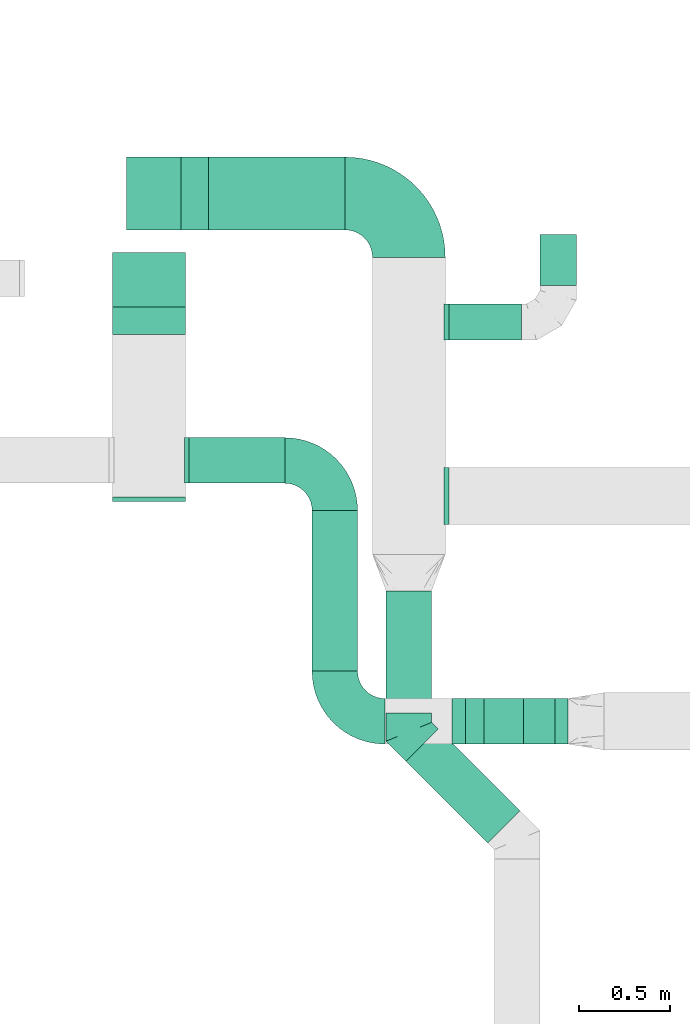
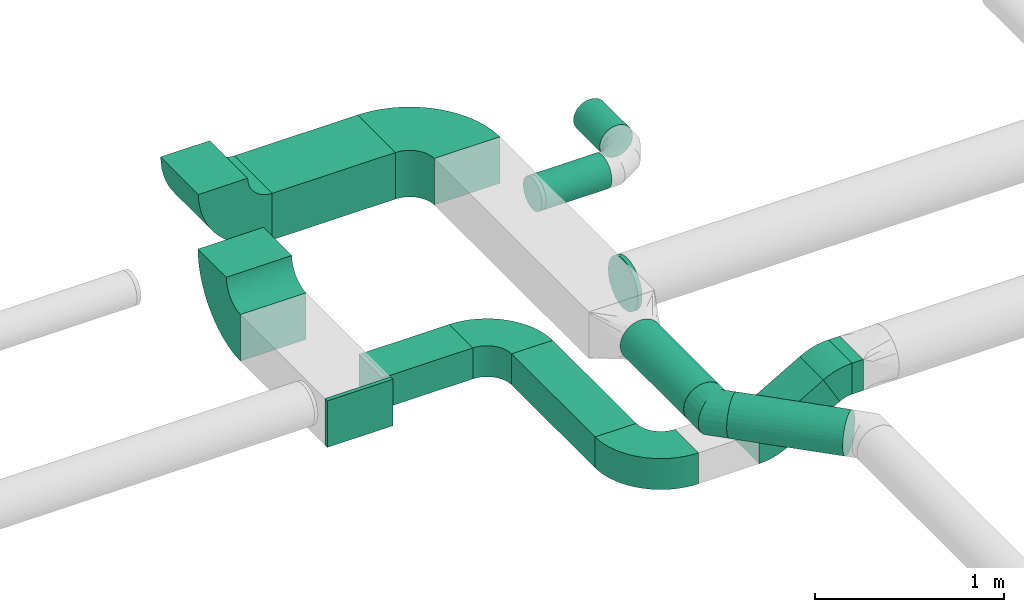
# One storey, part 45 of 92: 12 flow fittings, 9 flow segments.
"""IFC2X3 building model written with IfcOpenShell, lengths in millimetres."""

from ifc_helpers import new_model, entity, si_unit, converted_unit, derived_unit, direction, frame, frame_2d, origin, origin_2d_with_axis, place, context, subcontext, project, spatial, polyline, circle_curve, parameter, trimmed, segment, composite_curve, rectangle, circle, outline, extrude, faceted_brep, source, transform, mapped, material, type_object, type_shapes, element, save


model = new_model("IFC2X3")

# Units and contexts
model_context = context("Model", 3, precision=0.01, world=origin(), true_north=direction((6.12303176911189e-17, 1.0)))
body_context = subcontext(model_context, "Body", "Model", "MODEL_VIEW")
ifc_project = project(units=[si_unit("LENGTHUNIT", "METRE", prefix="MILLI"), si_unit("AREAUNIT", "SQUARE_METRE"), si_unit("VOLUMEUNIT", "CUBIC_METRE"), converted_unit("PLANEANGLEUNIT", "DEGREE", entity("IfcRatioMeasure", 0.0174532925199433), si_unit("PLANEANGLEUNIT", "RADIAN"), dimensions=[0, 0, 0, 0, 0, 0, 0]), si_unit("MASSUNIT", "GRAM", prefix="KILO"), derived_unit("MASSDENSITYUNIT", [(si_unit("MASSUNIT", "GRAM", prefix="KILO"), 1), (si_unit("LENGTHUNIT", "METRE"), -3)]), derived_unit("MOMENTOFINERTIAUNIT", [(si_unit("LENGTHUNIT", "METRE"), 4)]), si_unit("TIMEUNIT", "SECOND"), si_unit("FREQUENCYUNIT", "HERTZ"), si_unit("THERMODYNAMICTEMPERATUREUNIT", "DEGREE_CELSIUS"), derived_unit("THERMALTRANSMITTANCEUNIT", [(si_unit("MASSUNIT", "GRAM", prefix="KILO"), 1), (si_unit("THERMODYNAMICTEMPERATUREUNIT", "KELVIN"), -1), (si_unit("TIMEUNIT", "SECOND"), -3)]), derived_unit("VOLUMETRICFLOWRATEUNIT", [(si_unit("LENGTHUNIT", "METRE"), 3), (si_unit("TIMEUNIT", "SECOND"), -1)]), derived_unit("MASSFLOWRATEUNIT", [(si_unit("MASSUNIT", "GRAM", prefix="KILO"), 1), (si_unit("TIMEUNIT", "SECOND"), -1)]), derived_unit("ROTATIONALFREQUENCYUNIT", [(si_unit("TIMEUNIT", "SECOND"), -1)]), si_unit("ELECTRICCURRENTUNIT", "AMPERE"), si_unit("ELECTRICVOLTAGEUNIT", "VOLT"), si_unit("POWERUNIT", "WATT"), si_unit("FORCEUNIT", "NEWTON", prefix="KILO"), si_unit("ILLUMINANCEUNIT", "LUX"), si_unit("LUMINOUSFLUXUNIT", "LUMEN"), si_unit("LUMINOUSINTENSITYUNIT", "CANDELA"), derived_unit("USERDEFINED", [(si_unit("MASSUNIT", "GRAM", prefix="KILO"), -1), (si_unit("LENGTHUNIT", "METRE"), -2), (si_unit("TIMEUNIT", "SECOND"), 3), (si_unit("LUMINOUSFLUXUNIT", "LUMEN"), 1)]), derived_unit("LINEARVELOCITYUNIT", [(si_unit("LENGTHUNIT", "METRE"), 1), (si_unit("TIMEUNIT", "SECOND"), -1)]), si_unit("PRESSUREUNIT", "PASCAL"), derived_unit("USERDEFINED", [(si_unit("LENGTHUNIT", "METRE"), -2), (si_unit("MASSUNIT", "GRAM", prefix="KILO"), 1), (si_unit("TIMEUNIT", "SECOND"), -2)]), derived_unit("LINEARFORCEUNIT", [(si_unit("MASSUNIT", "GRAM", prefix="KILO"), 1), (si_unit("LENGTHUNIT", "METRE"), 1), (si_unit("TIMEUNIT", "SECOND"), -2), (si_unit("LENGTHUNIT", "METRE"), -1)]), derived_unit("PLANARFORCEUNIT", [(si_unit("MASSUNIT", "GRAM", prefix="KILO"), 1), (si_unit("LENGTHUNIT", "METRE"), 1), (si_unit("TIMEUNIT", "SECOND"), -2), (si_unit("LENGTHUNIT", "METRE"), -2)])], contexts=[model_context])

# Site, building, storey
site_placement = place(None, origin())
site = spatial("IfcSite", under=ifc_project, at=site_placement, CompositionType="ELEMENT")
building_placement = place(site_placement, origin())
building = spatial("IfcBuilding", under=site, at=building_placement, CompositionType="ELEMENT")
storey_placement = place(building_placement, frame((0.0, 0.0, 4200.0)))
storey = spatial("IfcBuildingStorey", under=building, at=storey_placement, CompositionType="ELEMENT", Elevation=4200.0)

# Flow segments
duct_segment_type_1 = type_object("IfcDuctSegmentType", PredefinedType="NOTDEFINED")
flow_segment_1_placement = place(storey_placement, frame((25153.23, 10107.66, 2950.0)))
element("IfcFlowSegment", 1, at=flow_segment_1_placement, inside=storey, type_object=duct_segment_type_1, context=body_context, shape_type="SweptSolid", body=[
    extrude(rectangle(XDim=525.000000000011, YDim=249.999999999999, at=origin_2d_with_axis()), frame((262.5, 125.0, 0.0), z_axis=(0.0, 0.0, 1.0), x_axis=(-1.0, 0.0, 0.0)), (0.0, 0.0, 1.0), 200.0),
])
flow_segment_2_placement = place(storey_placement, frame((25828.23, 9074.98, 2950.0)))
element("IfcFlowSegment", 2, at=flow_segment_2_placement, inside=storey, type_object=duct_segment_type_1, context=body_context, shape_type="SweptSolid", body=[
    extrude(rectangle(XDim=882.679418653186, YDim=249.999999999999, at=origin_2d_with_axis()), frame((125.0, 441.34, 0.0), z_axis=(0.0, 0.0, 1.0), x_axis=(0.0, -1.0, 0.0)), (0.0, 0.0, 1.0), 200.0),
])
flow_segment_3_placement = place(storey_placement, frame((25258.28, 11498.95, 3150.0)))
element("IfcFlowSegment", 3, at=flow_segment_3_placement, inside=storey, type_object=duct_segment_type_1, context=body_context, shape_type="SweptSolid", body=[
    extrude(rectangle(XDim=751.716213554857, YDim=400.0, at=origin_2d_with_axis()), frame((375.86, 200.0, 0.0), z_axis=(0.0, 0.0, 1.0), x_axis=(-1.0, 0.0, 0.0)), (0.0, 0.0, 1.0), 300.000000000001),
])
flow_segment_4_placement = place(storey_placement, frame((27164.02, 8674.98, 3200.0)))
element("IfcFlowSegment", 4, at=flow_segment_4_placement, inside=storey, type_object=duct_segment_type_1, context=body_context, shape_type="SweptSolid", body=[
    extrude(rectangle(XDim=69.2099790961587, YDim=250.000000000001, at=origin_2d_with_axis()), frame((34.6, 125.0, 0.0), z_axis=(0.0, 0.0, 1.0), x_axis=(-1.0, 0.0, 0.0)), (0.0, 0.0, 1.0), 200.0),
])
flow_segment_5_placement = place(storey_placement, frame((26672.04, 8674.98, 2996.89)))
element("IfcFlowSegment", 5, at=flow_segment_5_placement, inside=storey, type_object=duct_segment_type_1, context=body_context, shape_type="SweptSolid", body=[
    extrude(rectangle(XDim=199.999999999997, YDim=249.999999999999, at=frame_2d((0.0, 0.0), x_axis=(0.0, 1.0))), frame((50.0, 125.0, 86.6), z_axis=(0.866025410712621, 0.0, 0.499999988000036), x_axis=(0.0, 1.0, 0.0)), (0.0, 0.0, 1.0), 366.025419497303),
])
duct_segment_type_2 = type_object("IfcDuctSegmentType", PredefinedType="NOTDEFINED")
flow_segment_6_placement = place(storey_placement, frame((26233.4, 8845.92, 3198.4)))
element("IfcFlowSegment", 6, at=flow_segment_6_placement, inside=storey, type_object=duct_segment_type_2, context=body_context, shape_type="SweptSolid", body=[
    extrude(circle(Radius=125.0, at=origin_2d_with_axis()), frame((126.6, 0.0, 126.6), z_axis=(0.0, 1.0, 0.0), x_axis=(1.0, 0.0, 0.0)), (0.0, 0.0, 1.0), 670.730813828695),
])
flow_segment_7_placement = place(storey_placement, frame((26343.24, 8130.6, 3198.4)))
element("IfcFlowSegment", 7, at=flow_segment_7_placement, inside=storey, type_object=duct_segment_type_2, context=body_context, shape_type="SweptSolid", body=[
    extrude(circle(Radius=125.0, at=origin_2d_with_axis()), frame((89.98, 538.54, 126.6), z_axis=(0.70710678118656, -0.707106781186536, 0.0), x_axis=(-0.707106781186536, -0.70710678118656, 0.0)), (0.0, 0.0, 1.0), 634.350288425403),
])
flow_segment_8_placement = place(storey_placement, frame((26580.0, 10891.65, 3198.4)))
element("IfcFlowSegment", 8, at=flow_segment_8_placement, inside=storey, type_object=duct_segment_type_2, context=body_context, shape_type="SweptSolid", body=[
    extrude(circle(Radius=100.0, at=origin_2d_with_axis()), frame((0.0, 101.6, 101.6), z_axis=(1.0, 0.0, 0.0), x_axis=(0.0, -1.0, 0.0)), (0.0, 0.0, 1.0), 400.0),
])
flow_segment_9_placement = place(storey_placement, frame((27078.4, 11193.24, 3198.4)))
element("IfcFlowSegment", 9, at=flow_segment_9_placement, inside=storey, type_object=duct_segment_type_2, context=body_context, shape_type="SweptSolid", body=[
    extrude(circle(Radius=100.0, at=origin_2d_with_axis()), frame((101.6, 0.0, 101.6), z_axis=(0.0, 1.0, 0.0), x_axis=(1.0, 0.0, 0.0)), (0.0, 0.0, 1.0), 280.000000000008),
])

# Flow fittings
ifc_material = material()
duct_fitting_type_1 = type_object("IfcDuctFittingType", PredefinedType="NOTDEFINED", material=ifc_material)
shared_shape_1 = source(origin(), body_context, "Body", "SweptSolid", [
    extrude(rectangle(XDim=250.0, YDim=26.0960000000122, at=origin_2d_with_axis()), frame((6.95, 0.0, -100.0), z_axis=(0.0, 0.0, 1.0), x_axis=(0.0, -1.0, 0.0)), (0.0, 0.0, 1.0), 200.0),
])
type_shapes(duct_fitting_type_1, [shared_shape_1])
flow_fitting_1_placement = place(storey_placement, frame((25133.23, 10232.66, 3050.0), z_axis=(0.0, 0.0, -1.0), x_axis=(1.0, 0.0, 0.0)))
element("IfcFlowFitting", 10, at=flow_fitting_1_placement, inside=storey, type_object=duct_fitting_type_1, material=ifc_material, context=body_context, shape_type="MappedRepresentation", body=[
    mapped(shared_shape_1, transform((0.0, 0.0, 0.0), scale=1.0)),
])
duct_fitting_type_2 = type_object("IfcDuctFittingType", PredefinedType="NOTDEFINED", material=ifc_material)
shared_shape_2 = source(origin(), body_context, "Body", "SweptSolid", [
    extrude(rectangle(XDim=24.9999999999999, YDim=400.0, at=origin_2d_with_axis()), frame((12.5, 0.0, -150.0)), (0.0, 0.0, 1.0), 300.0),
])
type_shapes(duct_fitting_type_2, [shared_shape_2])
flow_fitting_2_placement = place(storey_placement, frame((24933.23, 10032.07, 3050.0), z_axis=(0.0, 0.0, 1.0), x_axis=(0.0, -1.0, 0.0)))
element("IfcFlowFitting", 11, at=flow_fitting_2_placement, inside=storey, type_object=duct_fitting_type_2, material=ifc_material, context=body_context, shape_type="MappedRepresentation", body=[
    mapped(shared_shape_2, transform((0.0, 0.0, 0.0), scale=1.0)),
])
duct_fitting_type_3 = type_object("IfcDuctFittingType", PredefinedType="NOTDEFINED", material=ifc_material)
shared_shape_3 = source(origin(), body_context, "Body", "Brep", [
    faceted_brep([(20.0, 0.0, -100.0), (20.0, 25.88, -96.59), (20.0, 50.0, -86.6), (20.0, 70.71, -70.71), (20.0, 86.6, -50.0), (20.0, 96.59, -25.88), (20.0, 100.0, 0.0), (20.0, 96.59, 25.88), (20.0, 86.6, 50.0), (20.0, 70.71, 70.71), (20.0, 50.0, 86.6), (20.0, 25.88, 96.59), (20.0, 0.0, 100.0), (20.0, -25.88, 96.59), (20.0, -50.0, 86.6), (20.0, -70.71, 70.71), (20.0, -86.6, 50.0), (20.0, -96.59, 25.88), (20.0, -100.0, 0.0), (20.0, -96.59, -25.88), (20.0, -86.6, -50.0), (20.0, -70.71, -70.71), (20.0, -50.0, -86.6), (20.0, -25.88, -96.59), (0.0, 0.0, 100.0), (-6.1, 0.0, 100.0), (-6.1, -25.88, 96.59), (0.0, -25.88, 96.59), (-6.1, -50.0, 86.6), (0.0, -50.0, 86.6), (0.0, -70.71, 70.71), (-6.1, -70.71, 70.71), (0.0, -86.6, 50.0), (-6.1, -86.6, 50.0), (-6.1, -96.59, 25.88), (0.0, -96.59, 25.88), (-6.1, -100.0, 0.0), (0.0, -100.0, 0.0), (-6.1, -96.59, -25.88), (0.0, -96.59, -25.88), (-6.1, -86.6, -50.0), (0.0, -86.6, -50.0), (0.0, -70.71, -70.71), (-6.1, -70.71, -70.71), (0.0, -50.0, -86.6), (-6.1, -50.0, -86.6), (-6.1, -25.88, -96.59), (0.0, -25.88, -96.59), (-6.1, 0.0, -100.0), (0.0, 0.0, -100.0), (-6.1, 25.88, -96.59), (0.0, 25.88, -96.59), (-6.1, 50.0, -86.6), (0.0, 50.0, -86.6), (0.0, 70.71, -70.71), (-6.1, 70.71, -70.71), (0.0, 86.6, -50.0), (-6.1, 86.6, -50.0), (-6.1, 96.59, -25.88), (0.0, 96.59, -25.88), (-6.1, 100.0, 0.0), (0.0, 100.0, 0.0), (-6.1, 96.59, 25.88), (0.0, 96.59, 25.88), (-6.1, 86.6, 50.0), (0.0, 86.6, 50.0), (0.0, 70.71, 70.71), (-6.1, 70.71, 70.71), (0.0, 50.0, 86.6), (-6.1, 50.0, 86.6), (-6.1, 25.88, 96.59), (0.0, 25.88, 96.59)], [[[0, 1, 2, 3, 4, 5, 6, 7, 8, 9, 10, 11, 12, 13, 14, 15, 16, 17, 18, 19, 20, 21, 22, 23]], [[13, 12, 24, 25, 26, 27]], [[14, 13, 27, 26, 28, 29]], [[30, 15, 14, 29, 28, 31]], [[17, 16, 32, 33, 34, 35]], [[18, 17, 35, 34, 36, 37]], [[32, 16, 15, 30, 31, 33]], [[19, 18, 37, 36, 38, 39]], [[20, 19, 39, 38, 40, 41]], [[42, 21, 20, 41, 40, 43]], [[23, 22, 44, 45, 46, 47]], [[0, 23, 47, 46, 48, 49]], [[44, 22, 21, 42, 43, 45]], [[1, 0, 49, 48, 50, 51]], [[2, 1, 51, 50, 52, 53]], [[54, 3, 2, 53, 52, 55]], [[5, 4, 56, 57, 58, 59]], [[6, 5, 59, 58, 60, 61]], [[56, 4, 3, 54, 55, 57]], [[7, 6, 61, 60, 62, 63]], [[8, 7, 63, 62, 64, 65]], [[66, 9, 8, 65, 64, 67]], [[11, 10, 68, 69, 70, 71]], [[12, 11, 71, 70, 25, 24]], [[68, 10, 9, 66, 67, 69]], [[46, 45, 43, 40, 38, 36, 34, 33, 31, 28, 26, 25, 70, 69, 67, 64, 62, 60, 58, 57, 55, 52, 50, 48]]]),
])
type_shapes(duct_fitting_type_3, [shared_shape_3])
flow_fitting_3_placement = place(storey_placement, frame((26560.0, 10993.24, 3300.0), z_axis=(0.0, 0.0, -1.0), x_axis=(1.0, 0.0, 0.0)))
element("IfcFlowFitting", 12, at=flow_fitting_3_placement, inside=storey, type_object=duct_fitting_type_3, material=ifc_material, context=body_context, shape_type="MappedRepresentation", body=[
    mapped(shared_shape_3, transform((0.0, 0.0, 0.0), scale=1.0)),
])
duct_fitting_type_4 = type_object("IfcDuctFittingType", PredefinedType="NOTDEFINED", material=ifc_material)
shared_shape_4 = source(origin(), body_context, "Body", "Brep", [
    faceted_brep([(-103.55, 0.0, -125.0), (-103.55, -32.35, -120.74), (-103.55, -62.5, -108.25), (-103.55, -88.39, -88.39), (-103.55, -108.25, -62.5), (-103.55, -120.74, -32.35), (-103.55, -125.0, 0.0), (-103.55, -120.74, 32.35), (-103.55, -108.25, 62.5), (-103.55, -88.39, 88.39), (-103.55, -62.5, 108.25), (-103.55, -32.35, 120.74), (-103.55, 0.0, 125.0), (-103.55, 32.35, 120.74), (-103.55, 62.5, 108.25), (-103.55, 88.39, 88.39), (-103.55, 108.25, 62.5), (-103.55, 120.74, 32.35), (-103.55, 125.0, 0.0), (-103.55, 120.74, -32.35), (-103.55, 108.25, -62.5), (-103.55, 88.39, -88.39), (-103.55, 62.5, -108.25), (-103.55, 32.35, -120.74), (-13.4, 32.35, 120.74), (-25.89, 62.5, 108.25), (0.0, 0.0, 125.0), (-36.61, 88.39, 88.39), (-44.84, 108.25, 62.5), (-50.01, 120.74, 32.35), (-51.78, 125.0, 0.0), (-50.01, 120.74, -32.35), (-44.84, 108.25, -62.5), (-36.61, 88.39, -88.39), (-13.4, 32.35, -120.74), (0.0, 0.0, -125.0), (-25.89, 62.5, -108.25), (13.4, -32.35, -120.74), (25.89, -62.5, -108.25), (36.61, -88.39, -88.39), (44.84, -108.25, -62.5), (50.01, -120.74, -32.35), (51.78, -125.0, 0.0), (50.01, -120.74, 32.35), (44.84, -108.25, 62.5), (36.61, -88.39, 88.39), (25.89, -62.5, 108.25), (13.4, -32.35, 120.74), (73.22, 73.22, 125.0), (50.35, 96.1, 120.74), (29.03, 117.42, 108.25), (10.72, 135.72, 88.39), (-3.32, 149.77, 62.5), (-12.15, 158.6, 32.35), (-15.17, 161.61, 0.0), (-12.15, 158.6, -32.35), (-3.32, 149.77, -62.5), (10.72, 135.72, -88.39), (29.03, 117.42, -108.25), (50.35, 96.1, -120.74), (73.22, 73.22, -125.0), (96.1, 50.35, -120.74), (117.42, 29.03, -108.25), (135.72, 10.72, -88.39), (149.77, -3.32, -62.5), (158.6, -12.15, -32.35), (161.61, -15.17, 0.0), (158.6, -12.15, 32.35), (149.77, -3.32, 62.5), (135.72, 10.72, 88.39), (117.42, 29.03, 108.25), (96.1, 50.35, 120.74)], [[[0, 1, 2, 3, 4, 5, 6, 7, 8, 9, 10, 11, 12, 13, 14, 15, 16, 17, 18, 19, 20, 21, 22, 23]], [[24, 25, 14, 13]], [[26, 24, 13, 12]], [[14, 25, 27, 15]], [[28, 29, 17, 16]], [[28, 16, 15, 27]], [[30, 18, 17, 29]], [[31, 32, 20, 19]], [[30, 31, 19, 18]], [[32, 33, 21, 20]], [[34, 35, 0, 23]], [[36, 34, 23, 22]], [[33, 36, 22, 21]], [[1, 0, 35, 37]], [[2, 1, 37, 38]], [[38, 39, 3, 2]], [[5, 4, 40, 41]], [[6, 5, 41, 42]], [[39, 40, 4, 3]], [[6, 42, 43, 7]], [[7, 43, 44, 8]], [[8, 44, 45, 9]], [[9, 45, 46, 10]], [[10, 46, 47, 11]], [[26, 12, 11, 47]], [[24, 26, 48, 49]], [[25, 24, 49, 50]], [[27, 25, 50, 51]], [[29, 28, 52, 53]], [[30, 29, 53, 54]], [[51, 52, 28, 27]], [[30, 54, 55, 31]], [[31, 55, 56, 32]], [[57, 33, 32, 56]], [[36, 58, 59, 34]], [[34, 59, 60, 35]], [[58, 36, 33, 57]], [[35, 60, 61, 37]], [[37, 61, 62, 38]], [[63, 39, 38, 62]], [[40, 64, 65, 41]], [[41, 65, 66, 42]], [[64, 40, 39, 63]], [[43, 42, 66, 67]], [[44, 43, 67, 68]], [[68, 69, 45, 44]], [[47, 46, 70, 71]], [[26, 47, 71, 48]], [[69, 70, 46, 45]], [[59, 58, 57, 56, 55, 54, 53, 52, 51, 50, 49, 48, 71, 70, 69, 68, 67, 66, 65, 64, 63, 62, 61, 60]]]),
])
type_shapes(duct_fitting_type_4, [shared_shape_4])
flow_fitting_4_placement = place(storey_placement, frame((26360.0, 8742.37, 3325.0), z_axis=(0.0, 0.0, 1.0), x_axis=(0.0, -1.0, 0.0)))
element("IfcFlowFitting", 13, at=flow_fitting_4_placement, inside=storey, type_object=duct_fitting_type_4, material=ifc_material, context=body_context, shape_type="MappedRepresentation", body=[
    mapped(shared_shape_4, transform((0.0, 0.0, 0.0), scale=1.0)),
])
duct_fitting_type_5 = type_object("IfcDuctFittingType", PredefinedType="NOTDEFINED", material=ifc_material)
shared_shape_5 = source(origin(), body_context, "Body", "Brep", [
    faceted_brep([(20.0, 0.0, -157.5), (20.0, 40.76, -152.13), (20.0, 78.75, -136.4), (20.0, 111.37, -111.37), (20.0, 136.4, -78.75), (20.0, 152.13, -40.76), (20.0, 157.5, 0.0), (20.0, 152.13, 40.76), (20.0, 136.4, 78.75), (20.0, 111.37, 111.37), (20.0, 78.75, 136.4), (20.0, 40.76, 152.13), (20.0, 0.0, 157.5), (20.0, -40.76, 152.13), (20.0, -78.75, 136.4), (20.0, -111.37, 111.37), (20.0, -136.4, 78.75), (20.0, -152.13, 40.76), (20.0, -157.5, 0.0), (20.0, -152.13, -40.76), (20.0, -136.4, -78.75), (20.0, -111.37, -111.37), (20.0, -78.75, -136.4), (20.0, -40.76, -152.13), (0.0, 0.0, 157.5), (-6.1, 0.0, 157.5), (-6.1, -40.76, 152.13), (0.0, -40.76, 152.13), (-6.1, -78.75, 136.4), (0.0, -78.75, 136.4), (0.0, -111.37, 111.37), (-6.1, -111.37, 111.37), (0.0, -136.4, 78.75), (-6.1, -136.4, 78.75), (-6.1, -152.13, 40.76), (0.0, -152.13, 40.76), (-6.1, -157.5, 0.0), (0.0, -157.5, 0.0), (-6.1, -152.13, -40.76), (0.0, -152.13, -40.76), (-6.1, -136.4, -78.75), (0.0, -136.4, -78.75), (0.0, -111.37, -111.37), (-6.1, -111.37, -111.37), (0.0, 0.0, -157.5), (0.0, -40.76, -152.13), (-6.1, -40.76, -152.13), (-6.1, 0.0, -157.5), (0.0, -78.75, -136.4), (-6.1, -78.75, -136.4), (-6.1, 40.76, -152.13), (0.0, 40.76, -152.13), (-6.1, 78.75, -136.4), (0.0, 78.75, -136.4), (0.0, 111.37, -111.37), (-6.1, 111.37, -111.37), (0.0, 136.4, -78.75), (-6.1, 136.4, -78.75), (-6.1, 152.13, -40.76), (0.0, 152.13, -40.76), (-6.1, 157.5, 0.0), (0.0, 157.5, 0.0), (-6.1, 152.13, 40.76), (0.0, 152.13, 40.76), (-6.1, 136.4, 78.75), (0.0, 136.4, 78.75), (0.0, 111.37, 111.37), (-6.1, 111.37, 111.37), (0.0, 78.75, 136.4), (-6.1, 78.75, 136.4), (-6.1, 40.76, 152.13), (0.0, 40.76, 152.13)], [[[0, 1, 2, 3, 4, 5, 6, 7, 8, 9, 10, 11, 12, 13, 14, 15, 16, 17, 18, 19, 20, 21, 22, 23]], [[13, 12, 24, 25, 26, 27]], [[14, 13, 27, 26, 28, 29]], [[30, 15, 14, 29, 28, 31]], [[17, 16, 32, 33, 34, 35]], [[18, 17, 35, 34, 36, 37]], [[32, 16, 15, 30, 31, 33]], [[19, 18, 37, 36, 38, 39]], [[20, 19, 39, 38, 40, 41]], [[42, 21, 20, 41, 40, 43]], [[44, 0, 23, 45, 46, 47]], [[48, 49, 46, 45, 23, 22]], [[22, 21, 42, 43, 49, 48]], [[1, 0, 44, 47, 50, 51]], [[2, 1, 51, 50, 52, 53]], [[54, 3, 2, 53, 52, 55]], [[5, 4, 56, 57, 58, 59]], [[6, 5, 59, 58, 60, 61]], [[56, 4, 3, 54, 55, 57]], [[7, 6, 61, 60, 62, 63]], [[8, 7, 63, 62, 64, 65]], [[66, 9, 8, 65, 64, 67]], [[11, 10, 68, 69, 70, 71]], [[12, 11, 71, 70, 25, 24]], [[68, 10, 9, 66, 67, 69]], [[46, 49, 43, 40, 38, 36, 34, 33, 31, 28, 26, 25, 70, 69, 67, 64, 62, 60, 58, 57, 55, 52, 50, 47]]]),
])
type_shapes(duct_fitting_type_5, [shared_shape_5])
flow_fitting_5_placement = place(storey_placement, frame((26560.0, 10037.96, 3300.0), z_axis=(0.0, 0.0, -1.0), x_axis=(1.0, 0.0, 0.0)))
element("IfcFlowFitting", 14, at=flow_fitting_5_placement, inside=storey, type_object=duct_fitting_type_5, material=ifc_material, context=body_context, shape_type="MappedRepresentation", body=[
    mapped(shared_shape_5, transform((0.0, 0.0, 0.0), scale=1.0)),
])
duct_fitting_type_6 = type_object("IfcDuctFittingType", PredefinedType="NOTDEFINED", material=ifc_material)
shared_shape_6 = source(origin(), body_context, "Body", "SweptSolid", [
    extrude(outline(composite_curve([segment(polyline([(-262.5, -137.5), (-12.5, -137.5)]), True, "CONTINUOUS"), segment(trimmed(circle_curve(frame_2d((137.5, -137.5), x_axis=(0.0, 1.0)), 150.0), [parameter(0.0)], [parameter(90.0000000000001)], True, "PARAMETER"), False, "CONTINUOUS"), segment(polyline([(137.5, 12.5), (137.5, 262.5)]), True, "CONTINUOUS"), segment(trimmed(circle_curve(frame_2d((137.5, -137.5), x_axis=(0.0, 1.0)), 400.0), [parameter(0.0)], [parameter(90.0000000000001)], True, "PARAMETER"), True, "CONTINUOUS")], self_intersect=False)), frame((-137.5, 137.5, -100.0), z_axis=(0.0, 0.0, 1.0), x_axis=(-1.0, 0.0, 0.0)), (0.0, 0.0, 1.0), 200.0),
])
type_shapes(duct_fitting_type_6, [shared_shape_6])
for number, where, z_axis, x_axis in (
    (15, (25953.23, 10232.66, 3050.0), (0.0, 0.0, 1.0), (0.0, 1.0, 0.0)),
    (16, (25953.23, 8799.98, 3050.0), (0.0, 0.0, 1.0), (0.0, -1.0, 0.0)),
):
    element("IfcFlowFitting", number, at=place(storey_placement, frame(where, z_axis=z_axis, x_axis=x_axis)), inside=storey, type_object=duct_fitting_type_6, material=ifc_material, context=body_context, shape_type="MappedRepresentation", body=[
        mapped(shared_shape_6, transform((0.0, 0.0, 0.0), scale=1.0)),
    ])
duct_fitting_type_7 = type_object("IfcDuctFittingType", PredefinedType="NOTDEFINED", material=ifc_material)
shared_shape_7 = source(origin(), body_context, "Body", "SweptSolid", [
    extrude(outline(composite_curve([segment(polyline([(-375.0, -175.0), (25.0, -175.0)]), True, "CONTINUOUS"), segment(trimmed(circle_curve(frame_2d((175.0, -175.0), x_axis=(0.0, 1.0)), 150.0), [parameter(0.0)], [parameter(90.0000000000001)], True, "PARAMETER"), False, "CONTINUOUS"), segment(polyline([(175.0, -25.0), (175.0, 375.0)]), True, "CONTINUOUS"), segment(trimmed(circle_curve(frame_2d((175.0, -175.0), x_axis=(0.0, 1.0)), 550.0), [parameter(0.0)], [parameter(90.0)], True, "PARAMETER"), True, "CONTINUOUS")], self_intersect=False)), frame((-175.0, 175.0, -150.0), z_axis=(0.0, 0.0, 1.0), x_axis=(-1.0, 0.0, 0.0)), (0.0, 0.0, 1.0), 300.0),
])
type_shapes(duct_fitting_type_7, [shared_shape_7])
flow_fitting_6_placement = place(storey_placement, frame((26360.0, 11698.95, 3300.0), z_axis=(0.0, 0.0, 1.0), x_axis=(0.0, 1.0, 0.0)))
element("IfcFlowFitting", 17, at=flow_fitting_6_placement, inside=storey, type_object=duct_fitting_type_7, material=ifc_material, context=body_context, shape_type="MappedRepresentation", body=[
    mapped(shared_shape_7, transform((0.0, 0.0, 0.0), scale=1.0)),
])
duct_fitting_type_8 = type_object("IfcDuctFittingType", PredefinedType="NOTDEFINED", material=ifc_material)
shared_shape_8 = source(origin(), body_context, "Body", "SweptSolid", [
    extrude(outline(composite_curve([segment(polyline([(-116.75, -62.5), (83.25, -62.5)]), True, "CONTINUOUS"), segment(trimmed(circle_curve(frame_2d((233.25, -62.5), x_axis=(-0.86602541071267, 0.499999987999949)), 150.0), [parameter(0.0)], [parameter(29.999999206083)], True, "PARAMETER"), False, "CONTINUOUS"), segment(polyline([(103.35, 12.5), (-69.86, 112.5)]), True, "CONTINUOUS"), segment(trimmed(circle_curve(frame_2d((233.25, -62.5), x_axis=(-0.86602541071267, 0.499999987999949)), 350.0), [parameter(0.0)], [parameter(29.999999206083)], True, "PARAMETER"), True, "CONTINUOUS")], self_intersect=False)), frame((-4.49, 16.75, -125.0), z_axis=(0.0, 0.0, 1.0), x_axis=(-0.499999987999949, 0.866025410712671, 0.0)), (0.0, 0.0, 1.0), 250.0),
])
type_shapes(duct_fitting_type_8, [shared_shape_8])
for number, where, z_axis, x_axis in (
    (18, (27097.04, 8799.98, 3300.0), (0.0, -1.0, 0.0), (-1.0, 0.0, 0.0)),
    (19, (26664.02, 8799.98, 3050.0), (0.0, 1.0, 0.0), (-0.866025410712614, 0.0, -0.499999988000048)),
):
    element("IfcFlowFitting", number, at=place(storey_placement, frame(where, z_axis=z_axis, x_axis=x_axis)), inside=storey, type_object=duct_fitting_type_8, material=ifc_material, context=body_context, shape_type="MappedRepresentation", body=[
        mapped(shared_shape_8, transform((0.0, 0.0, 0.0), scale=1.0)),
    ])
duct_fitting_type_9 = type_object("IfcDuctFittingType", PredefinedType="NOTDEFINED", material=ifc_material)
shared_shape_9 = source(origin(), body_context, "Body", "SweptSolid", [
    extrude(outline(composite_curve([segment(polyline([(-300.0, -150.0), (0.0, -150.0)]), True, "CONTINUOUS"), segment(trimmed(circle_curve(frame_2d((150.0, -150.0), x_axis=(0.0, 1.0)), 150.0), [parameter(0.0)], [parameter(90.0)], True, "PARAMETER"), False, "CONTINUOUS"), segment(polyline([(150.0, 0.0), (150.0, 300.0)]), True, "CONTINUOUS"), segment(trimmed(circle_curve(frame_2d((150.0, -150.0), x_axis=(0.0, 1.0)), 450.0), [parameter(0.0)], [parameter(90.0000000000001)], True, "PARAMETER"), True, "CONTINUOUS")], self_intersect=False)), frame((-150.0, 150.0, -200.0), z_axis=(0.0, 0.0, 1.0), x_axis=(-1.0, 0.0, 0.0)), (0.0, 0.0, 1.0), 400.0),
])
type_shapes(duct_fitting_type_9, [shared_shape_9])
for number, where, z_axis, x_axis in (
    (20, (24933.23, 11224.99, 3050.0), (1.0, 0.0, 0.0), (0.0, 1.0, 0.0)),
    (21, (24958.28, 11698.95, 3300.0), (0.0, 1.0, 0.0), (-1.0, 0.0, 0.0)),
):
    element("IfcFlowFitting", number, at=place(storey_placement, frame(where, z_axis=z_axis, x_axis=x_axis)), inside=storey, type_object=duct_fitting_type_9, material=ifc_material, context=body_context, shape_type="MappedRepresentation", body=[
        mapped(shared_shape_9, transform((0.0, 0.0, 0.0), scale=1.0)),
    ])

save(model, "model.ifc")
